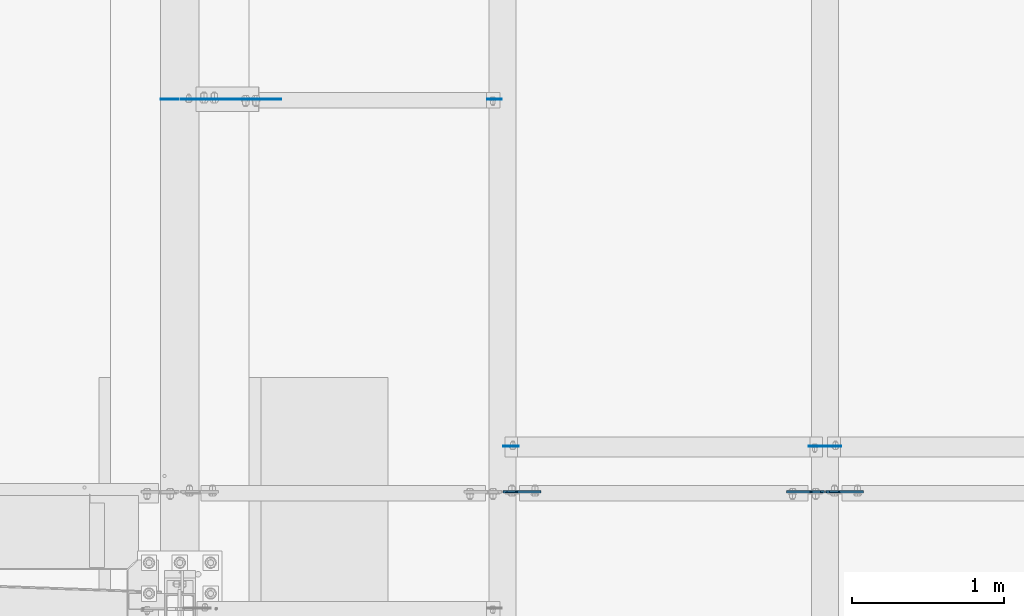
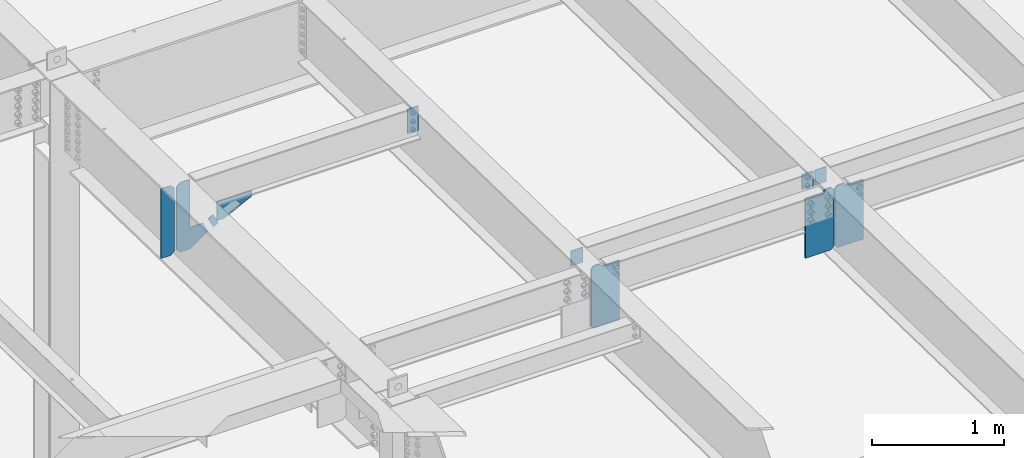
# One storey, part 1438 of 1763: 11 plates, 5 elements without a shape of their own.
"""IFC2X3 building model written with IfcOpenShell, lengths in millimetres."""

from ifc_helpers import new_model, si_unit, frame, origin_with_axes, place, context, subcontext, project, spatial, faceted_brep, material, type_object, element, aggregate, save


model = new_model("IFC2X3")

# Units and contexts
model_context = context("Model", 3, precision=1e-05, world=origin_with_axes())
body_context = subcontext(model_context, "Body", "Model", "MODEL_VIEW")
ifc_project = project(units=[si_unit("LENGTHUNIT", "METRE", prefix="MILLI"), si_unit("AREAUNIT", "SQUARE_METRE"), si_unit("VOLUMEUNIT", "CUBIC_METRE"), si_unit("MASSUNIT", "GRAM", prefix="KILO"), si_unit("TIMEUNIT", "SECOND"), si_unit("PLANEANGLEUNIT", "RADIAN"), si_unit("SOLIDANGLEUNIT", "STERADIAN"), si_unit("THERMODYNAMICTEMPERATUREUNIT", "DEGREE_CELSIUS"), si_unit("LUMINOUSINTENSITYUNIT", "LUMEN")], contexts=[model_context])

# Site, building, storey
site_placement = place(None, origin_with_axes())
site = spatial("IfcSite", under=ifc_project, at=site_placement, CompositionType="ELEMENT")
building_placement = place(site_placement, origin_with_axes())
building = spatial("IfcBuilding", under=site, at=building_placement, Name="Undefined", CompositionType="ELEMENT")
storey_placement = place(building_placement, origin_with_axes())
storey = spatial("IfcBuildingStorey", under=building, at=storey_placement, Name="Undefined", CompositionType="ELEMENT", Elevation=0.0)

# Assembly, plate
assembly_1_placement = place(storey_placement, origin_with_axes())
assembly_1 = element("IfcElementAssembly", 1, at=assembly_1_placement, inside=storey, Name="BEAM", AssemblyPlace="NOTDEFINED", PredefinedType="RIGID_FRAME")
ifc_material_1 = material(Name="STEEL/A36")
plate_type_1 = type_object("IfcPlateType", PredefinedType="NOTDEFINED")
plate_1_placement = place(assembly_1_placement, frame((-87090.6652500603, 11893.5500000143, 11230.1044846589), z_axis=(0.894427191199916, 0.0, 0.447213595099958), x_axis=(0.447213595099924, 0.0, -0.894427191199933)))
plate_1 = element("IfcPlate", 2, at=plate_1_placement, type_object=plate_type_1, material=ifc_material_1, Name="PLATE", context=body_context, shape_type="Brep", body=[
    faceted_brep([(1.81898940354586e-12, -3.17500000000291, 0.0), (0.0, -3.17500000000291, 50.7999992370605), (0.0, 3.17500000000291, 50.7999992370605), (-1.81898940354586e-12, 3.17499999997381, 0.0), (101.599998474121, -3.17500000000291, 50.7999992370605), (101.599998474121, 3.17500000000291, 50.7999992370605), (101.599990844785, -3.17499999999927, -1.81898940354586e-11), (101.599990844785, 3.17499999999927, -1.81898940354586e-11)], [[[0, 1, 2, 3]], [[1, 4, 5, 2]], [[4, 6, 7, 5]], [[6, 0, 3, 7]], [[5, 7, 3, 2]], [[6, 4, 1, 0]]]),
])
aggregate(assembly_1, [plate_1])

# Assembly, plates
assembly_2_placement = place(storey_placement, origin_with_axes())
assembly_2 = element("IfcElementAssembly", 3, at=assembly_2_placement, inside=storey, Name="BEAM", AssemblyPlace="NOTDEFINED", PredefinedType="RIGID_FRAME")
plate_type_2 = type_object("IfcPlateType", PredefinedType="NOTDEFINED")
plate_2_placement = place(assembly_2_placement, frame((-85253.8569165555, 11893.55, 11631.341471078), z_axis=(-1.0, 0.0, 0.0), x_axis=(0.0, 0.0, -1.0)))
plate_2 = element("IfcPlate", 4, at=plate_2_placement, type_object=plate_type_2, material=ifc_material_1, Name="PLATE", context=body_context, shape_type="Brep", body=[
    faceted_brep([(1.81898940354586e-12, -3.17500000000291, 0.0), (0.0, -3.17499999999927, 96.8375015258789), (0.0, 3.17499999999927, 96.8375015258789), (-1.81898940354586e-12, 3.17499999997381, 0.0), (228.600006103516, -3.17499999999927, 96.8375015258789), (228.600006103516, 3.17499999999927, 96.8375015258789), (228.600006103516, -3.17500000001019, -7.27595761418343e-12), (228.600006103516, 3.17499999999563, -7.27595761418343e-12)], [[[0, 1, 2, 3]], [[1, 4, 5, 2]], [[4, 6, 7, 5]], [[6, 0, 3, 7]], [[5, 7, 3, 2]], [[6, 4, 1, 0]]]),
])
plate_type_3 = type_object("IfcPlateType", PredefinedType="NOTDEFINED")
plate_3_placement = place(assembly_2_placement, frame((-85244.3319165555, 9607.55000000002, 11672.7824111605), z_axis=(1.0, 0.0, 0.0), x_axis=(0.0, 0.0, -1.0)))
plate_3 = element("IfcPlate", 5, at=plate_3_placement, type_object=plate_type_3, material=ifc_material_1, Name="PLATE", context=body_context, shape_type="Brep", body=[
    faceted_brep([(1.81898940354586e-12, -3.17500000000291, 0.0), (0.0, -3.17499999999927, 101.599998474121), (0.0, 3.17499999999927, 101.599998474121), (-1.81898940354586e-12, 3.17499999997381, 0.0), (139.699996948242, -3.17499999999927, 101.599998474121), (139.699996948242, 3.17499999999927, 101.599998474121), (139.699996948242, -3.17499999999927, 0.0), (139.699996948242, 3.17499999999927, 0.0)], [[[0, 1, 2, 3]], [[1, 4, 5, 2]], [[4, 6, 7, 5]], [[6, 0, 3, 7]], [[5, 7, 3, 2]], [[6, 4, 1, 0]]]),
])

assembly_3_placement = place(storey_placement, origin_with_axes())
assembly_3 = element("IfcElementAssembly", 6, at=assembly_3_placement, inside=storey, Name="BEAM", AssemblyPlace="NOTDEFINED", PredefinedType="RIGID_FRAME")
plate_4_placement = place(assembly_3_placement, frame((-83127.5140594126, 9607.55000000002, 11672.7824111605), z_axis=(-1.0, 0.0, 0.0), x_axis=(0.0, 0.0, -1.0)))
plate_4 = element("IfcPlate", 7, at=plate_4_placement, type_object=plate_type_3, material=ifc_material_1, Name="PLATE", context=body_context, shape_type="Brep", body=[
    faceted_brep([(1.81898940354586e-12, -3.17500000000291, 0.0), (0.0, -3.17499999999927, 101.599998474121), (0.0, 3.17499999999927, 101.599998474121), (-1.81898940354586e-12, 3.17499999997381, 0.0), (139.699996948242, -3.17499999999927, 101.599998474121), (139.699996948242, 3.17499999999927, 101.599998474121), (139.699996948242, -3.17499999999927, 0.0), (139.699996948242, 3.17499999999927, 0.0)], [[[0, 1, 2, 3]], [[1, 4, 5, 2]], [[4, 6, 7, 5]], [[6, 0, 3, 7]], [[5, 7, 3, 2]], [[6, 4, 1, 0]]]),
])
plate_5_placement = place(assembly_3_placement, frame((-83117.9890594126, 9607.55000000002, 11672.7824111605), z_axis=(1.0, 0.0, 0.0), x_axis=(0.0, 0.0, -1.0)))
plate_5 = element("IfcPlate", 8, at=plate_5_placement, type_object=plate_type_3, material=ifc_material_1, Name="PLATE", context=body_context, shape_type="Brep", body=[
    faceted_brep([(1.81898940354586e-12, -3.17500000000291, 0.0), (0.0, -3.17499999999927, 101.599998474121), (0.0, 3.17499999999927, 101.599998474121), (-1.81898940354586e-12, 3.17499999997381, 0.0), (139.699996948242, -3.17499999999927, 101.599998474121), (139.699996948242, 3.17499999999927, 101.599998474121), (139.699996948242, -3.17499999999927, 0.0), (139.699996948242, 3.17499999999927, 0.0)], [[[0, 1, 2, 3]], [[1, 4, 5, 2]], [[4, 6, 7, 5]], [[6, 0, 3, 7]], [[5, 7, 3, 2]], [[6, 4, 1, 0]]]),
])

# Assembly, plate
assembly_4_placement = place(storey_placement, origin_with_axes())
assembly_4 = element("IfcElementAssembly", 9, at=assembly_4_placement, inside=storey, Name="BEAM", AssemblyPlace="NOTDEFINED", PredefinedType="RIGID_FRAME")
plate_type_4 = type_object("IfcPlateType", PredefinedType="NOTDEFINED")
plate_6_placement = place(assembly_4_placement, frame((-87367.1997736983, 11893.550000049, 11007.2426003638), z_axis=(0.0, 0.0, 1.0), x_axis=(1.0, 0.0, 0.0)))
plate_6 = element("IfcPlate", 10, at=plate_6_placement, type_object=plate_type_4, material=ifc_material_1, Name="PLATE", context=body_context, shape_type="Brep", body=[
    faceted_brep([(0.0, -3.17500000000291, 31.75), (0.0, -3.17499999999927, 611.195617675781), (0.0, 3.17499999999927, 611.195617675781), (0.0, 3.17500000000291, 31.75), (31.75, -3.17499999999927, 642.945617675781), (31.75, 3.17499999999927, 642.945617675781), (118.762496948242, -3.17499999999927, 642.945617675781), (118.762496948242, 3.17499999999927, 642.945617675781), (118.762496948242, -3.17499999999927, 199.747741699219), (118.762496948242, 3.17499999999927, 199.747741699219), (230.306228637695, -3.17499999999927, 199.747741699219), (230.306228637695, 3.17499999999927, 199.747741699219), (275.743133544922, -3.17499999999927, 108.873931884766), (275.743133544922, 3.17499999999927, 108.873931884766), (118.762496948242, -3.17499999999927, 0.0), (118.762496948242, 3.17499999999927, 0.0), (31.7499999999036, -3.17499999997381, 9.42916855706244e-11), (31.7499999998854, 3.17500000000291, 9.42916855706244e-11)], [[[0, 1, 2, 3]], [[1, 4, 5, 2]], [[4, 6, 7, 5]], [[6, 8, 9, 7]], [[8, 10, 11, 9]], [[10, 12, 13, 11]], [[12, 14, 15, 13]], [[14, 16, 17, 15]], [[16, 0, 3, 17]], [[5, 7, 9, 11, 13, 15, 17, 3, 2]], [[16, 14, 12, 10, 8, 6, 4, 1, 0]]]),
])

assembly_5_placement = place(storey_placement, origin_with_axes())
assembly_5 = element("IfcElementAssembly", 11, at=assembly_5_placement, inside=storey, Name="BEAM", AssemblyPlace="NOTDEFINED", PredefinedType="RIGID_FRAME")
plate_type_5 = type_object("IfcPlateType", PredefinedType="NOTDEFINED")
plate_7_placement = place(assembly_5_placement, frame((-87014.777246411, 11893.5500000004, 11358.2914656381), z_axis=(1.0, 0.0, 0.0), x_axis=(0.0, 0.0, -1.0)))
plate_7 = element("IfcPlate", 12, at=plate_7_placement, type_object=plate_type_5, material=ifc_material_1, Name="PLATE", context=body_context, shape_type="Brep", body=[
    faceted_brep([(1.81898940354586e-12, -3.17500000000291, 0.0), (0.0, -3.17499999999927, 306.070465087891), (0.0, 3.17499999999927, 306.070465087891), (-1.81898940354586e-12, 3.17499999997381, 0.0), (50.7999992370605, -3.17499999999927, 306.070465087891), (50.7999992370605, 3.17499999999927, 306.070465087891), (172.922760009766, -3.17499999999927, 61.8249359130859), (172.922760009766, 3.17499999999927, 61.8249359130859), (172.922760009766, -3.17499999999927, 0.0), (172.922760009766, 3.17499999999927, 0.0)], [[[0, 1, 2, 3]], [[1, 4, 5, 2]], [[4, 6, 7, 5]], [[6, 8, 9, 7]], [[8, 0, 3, 9]], [[5, 7, 9, 3, 2]], [[8, 6, 4, 1, 0]]]),
])
aggregate(assembly_5, [plate_7])

# Plate
plate_type_6 = type_object("IfcPlateType", PredefinedType="NOTDEFINED")
plate_8_placement = place(assembly_4_placement, frame((-87383.6747736984, 11893.550000049, 11007.2426003638), z_axis=(0.0, 0.0, 1.0), x_axis=(-1.0, 0.0, 0.0)))
plate_8 = element("IfcPlate", 13, at=plate_8_placement, type_object=plate_type_6, material=ifc_material_1, Name="PLATE", context=body_context, shape_type="Brep", body=[
    faceted_brep([(0.0, -3.17500000000291, 31.75), (0.0, -3.17499999999927, 611.195556640625), (0.0, 3.17499999999927, 611.195556640625), (0.0, 3.17500000000291, 31.75), (31.75, -3.17499999999927, 642.945556640625), (31.75, 3.17499999999927, 642.945556640625), (118.762496948242, -3.17499999999927, 642.945556640625), (118.762496948242, 3.17499999999927, 642.945556640625), (118.762496948242, -3.17499999999927, 0.0), (118.762496948242, 3.17499999999927, 0.0), (31.7499999999036, -3.17499999997381, 9.42916855706244e-11), (31.7499999998854, 3.17500000000291, 9.42916855706244e-11)], [[[0, 1, 2, 3]], [[1, 4, 5, 2]], [[4, 6, 7, 5]], [[6, 8, 9, 7]], [[8, 10, 11, 9]], [[10, 0, 3, 11]], [[5, 7, 9, 11, 3, 2]], [[10, 8, 6, 4, 1, 0]]]),
])

aggregate(assembly_4, [plate_8, plate_6])

ifc_material_2 = material(Name="STEEL/A572-50")
plate_type_7 = type_object("IfcPlateType", PredefinedType="NOTDEFINED")
plate_9_placement = place(assembly_3_placement, frame((-83127.8140594126, 9305.92500001499, 11136.3348158671), z_axis=(0.0, 0.0, 1.0), x_axis=(-1.0, 0.0, 0.0)))
plate_9 = element("IfcPlate", 14, at=plate_9_placement, type_object=plate_type_7, material=ifc_material_2, Name="PLATE", context=body_context, shape_type="Brep", body=[
    faceted_brep([(83.8374938964844, -6.35000000000036, 573.93505859375), (83.8374938964844, -6.35000000000036, 561.869720450019), (83.8374938964844, 6.35000000000036, 561.869720450019), (83.8374938964844, 6.35000000000036, 573.93505859375), (84.8042238190683, -6.35000000000036, 557.009640931972), (84.8042238190683, 6.35000000000036, 557.009640931972), (87.5572377195494, -6.35000000000036, 552.889464463819), (87.5572377195494, 6.35000000000036, 552.889464463819), (91.6774141877104, -6.35000000000036, 550.136450563341), (91.6774141877104, 6.35000000000036, 550.136450563341), (96.5374937057495, -6.35000000000036, 549.169720640753), (96.5374937057495, 6.35000000000036, 549.169720640753), (247.649993896484, -6.35000000000036, 549.169720640753), (247.649993896484, 6.35000000000036, 549.169720640753), (0.0, -6.35000000000036, 550.12255859375), (23.8125, -6.35000000000036, 573.93505859375), (23.8125, 6.35000000000036, 573.93505859375), (0.0, 6.35000000000036, 550.12255859375), (0.0, -6.35000000000036, 23.8125), (0.0, 6.35000000000036, 23.8125), (23.8125, -6.35000000000036, 0.0), (23.8125, 6.35000000000036, 0.0), (247.649993896484, -6.34999999999854, 0.0), (247.649993896484, 6.34999999999854, 0.0)], [[[0, 1, 2, 3]], [[4, 5, 2, 1]], [[6, 7, 5, 4]], [[8, 9, 7, 6]], [[10, 11, 9, 8]], [[12, 13, 11, 10]], [[14, 15, 16, 17]], [[18, 14, 17, 19]], [[20, 18, 19, 21]], [[22, 20, 21, 23]], [[8, 6, 4, 1, 0, 15, 14, 18, 20, 22, 12, 10]], [[16, 15, 0, 3]], [[23, 21, 19, 17, 16, 3, 2, 5, 7, 9, 11, 13]], [[22, 23, 13, 12]]]),
])

plate_10_placement = place(assembly_3_placement, frame((-83117.6890594126, 9305.925, 11136.3348158675), z_axis=(0.0, 0.0, 1.0), x_axis=(1.0, 0.0, 0.0)))
plate_10 = element("IfcPlate", 15, at=plate_10_placement, type_object=plate_type_7, material=ifc_material_2, Name="PLATE", context=body_context, shape_type="Brep", body=[
    faceted_brep([(83.8374938964844, -6.35000000000036, 573.93505859375), (83.8374938964844, -6.35000000000036, 561.869720450019), (83.8374938964844, 6.35000000000036, 561.869720450019), (83.8374938964844, 6.35000000000036, 573.93505859375), (84.8042238190683, -6.35000000000036, 557.009640931972), (84.8042238190683, 6.35000000000036, 557.009640931972), (87.5572377195494, -6.35000000000036, 552.889464463819), (87.5572377195494, 6.35000000000036, 552.889464463819), (91.6774141877104, -6.35000000000036, 550.136450563341), (91.6774141877104, 6.35000000000036, 550.136450563341), (96.5374937057495, -6.35000000000036, 549.169720640753), (96.5374937057495, 6.35000000000036, 549.169720640753), (247.649993896484, -6.35000000000036, 549.169720640753), (247.649993896484, 6.35000000000036, 549.169720640753), (0.0, -6.35000000000036, 550.12255859375), (23.8125, -6.35000000000036, 573.93505859375), (23.8125, 6.35000000000036, 573.93505859375), (0.0, 6.35000000000036, 550.12255859375), (0.0, -6.35000000000036, 23.8125), (0.0, 6.35000000000036, 23.8125), (23.8125, -6.35000000000036, 0.0), (23.8125, 6.35000000000036, 0.0), (247.649993896484, -6.34999999999854, 0.0), (247.649993896484, 6.34999999999854, 0.0)], [[[0, 1, 2, 3]], [[4, 5, 2, 1]], [[6, 7, 5, 4]], [[8, 9, 7, 6]], [[10, 11, 9, 8]], [[12, 13, 11, 10]], [[14, 15, 16, 17]], [[18, 14, 17, 19]], [[20, 18, 19, 21]], [[22, 20, 21, 23]], [[8, 6, 4, 1, 0, 15, 14, 18, 20, 22, 12, 10]], [[16, 15, 0, 3]], [[23, 21, 19, 17, 16, 3, 2, 5, 7, 9, 11, 13]], [[22, 23, 13, 12]]]),
])

aggregate(assembly_3, [plate_9, plate_10, plate_4, plate_5])

plate_11_placement = place(assembly_2_placement, frame((-85244.0319165555, 9305.925, 11136.3348158674), z_axis=(0.0, 0.0, 1.0), x_axis=(1.0, 0.0, 0.0)))
plate_11 = element("IfcPlate", 16, at=plate_11_placement, type_object=plate_type_7, material=ifc_material_2, Name="PLATE", context=body_context, shape_type="Brep", body=[
    faceted_brep([(83.8374938964844, -6.35000000000036, 573.93505859375), (83.8374938964844, -6.35000000000036, 561.869720450019), (83.8374938964844, 6.35000000000036, 561.869720450019), (83.8374938964844, 6.35000000000036, 573.93505859375), (84.8042238190683, -6.35000000000036, 557.009640931972), (84.8042238190683, 6.35000000000036, 557.009640931972), (87.5572377195494, -6.35000000000036, 552.889464463819), (87.5572377195494, 6.35000000000036, 552.889464463819), (91.6774141877104, -6.35000000000036, 550.136450563341), (91.6774141877104, 6.35000000000036, 550.136450563341), (96.5374937057495, -6.35000000000036, 549.169720640753), (96.5374937057495, 6.35000000000036, 549.169720640753), (247.649993896484, -6.35000000000036, 549.169720640753), (247.649993896484, 6.35000000000036, 549.169720640753), (0.0, -6.35000000000036, 550.12255859375), (23.8125, -6.35000000000036, 573.93505859375), (23.8125, 6.35000000000036, 573.93505859375), (0.0, 6.35000000000036, 550.12255859375), (0.0, -6.35000000000036, 23.8125), (0.0, 6.35000000000036, 23.8125), (23.8125, -6.35000000000036, 0.0), (23.8125, 6.35000000000036, 0.0), (247.649993896484, -6.34999999999854, 0.0), (247.649993896484, 6.34999999999854, 0.0)], [[[0, 1, 2, 3]], [[4, 5, 2, 1]], [[6, 7, 5, 4]], [[8, 9, 7, 6]], [[10, 11, 9, 8]], [[12, 13, 11, 10]], [[14, 15, 16, 17]], [[18, 14, 17, 19]], [[20, 18, 19, 21]], [[22, 20, 21, 23]], [[8, 6, 4, 1, 0, 15, 14, 18, 20, 22, 12, 10]], [[16, 15, 0, 3]], [[23, 21, 19, 17, 16, 3, 2, 5, 7, 9, 11, 13]], [[22, 23, 13, 12]]]),
])

aggregate(assembly_2, [plate_11, plate_2, plate_3])

save(model, "model.ifc")
